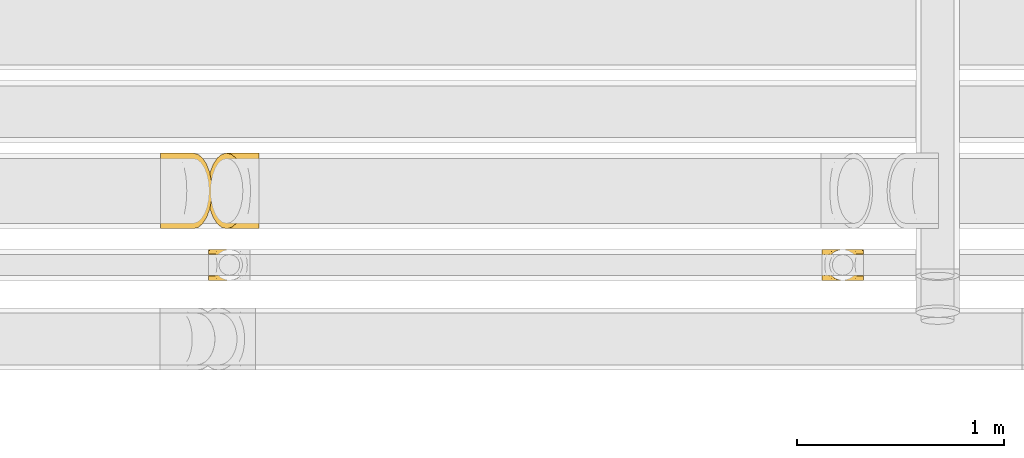
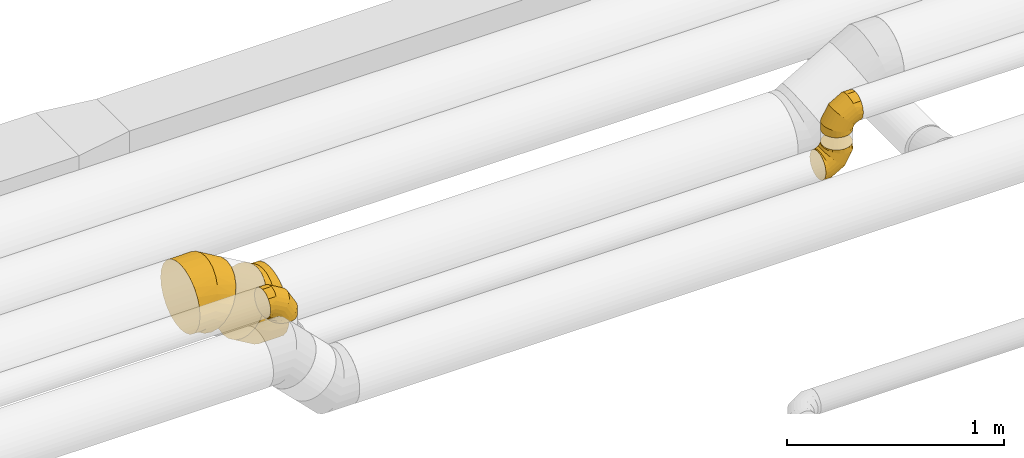
# One storey, part 15 of 92: 5 coverings.
"""IFC2X3 building model written with IfcOpenShell, lengths in millimetres."""

from ifc_helpers import new_model, entity, si_unit, converted_unit, derived_unit, direction, frame, origin, place, context, subcontext, project, spatial, faceted_brep, element, save


model = new_model("IFC2X3")

# Units and contexts
model_context = context("Model", 3, precision=0.01, world=origin(), true_north=direction((6.12303176911189e-17, 1.0)))
body_context = subcontext(model_context, "Body", "Model", "MODEL_VIEW")
ifc_project = project(units=[si_unit("LENGTHUNIT", "METRE", prefix="MILLI"), si_unit("AREAUNIT", "SQUARE_METRE"), si_unit("VOLUMEUNIT", "CUBIC_METRE"), converted_unit("PLANEANGLEUNIT", "DEGREE", entity("IfcRatioMeasure", 0.0174532925199433), si_unit("PLANEANGLEUNIT", "RADIAN"), dimensions=[0, 0, 0, 0, 0, 0, 0]), si_unit("MASSUNIT", "GRAM", prefix="KILO"), derived_unit("MASSDENSITYUNIT", [(si_unit("MASSUNIT", "GRAM", prefix="KILO"), 1), (si_unit("LENGTHUNIT", "METRE"), -3)]), derived_unit("MOMENTOFINERTIAUNIT", [(si_unit("LENGTHUNIT", "METRE"), 4)]), si_unit("TIMEUNIT", "SECOND"), si_unit("FREQUENCYUNIT", "HERTZ"), si_unit("THERMODYNAMICTEMPERATUREUNIT", "DEGREE_CELSIUS"), derived_unit("THERMALTRANSMITTANCEUNIT", [(si_unit("MASSUNIT", "GRAM", prefix="KILO"), 1), (si_unit("THERMODYNAMICTEMPERATUREUNIT", "KELVIN"), -1), (si_unit("TIMEUNIT", "SECOND"), -3)]), derived_unit("VOLUMETRICFLOWRATEUNIT", [(si_unit("LENGTHUNIT", "METRE"), 3), (si_unit("TIMEUNIT", "SECOND"), -1)]), derived_unit("MASSFLOWRATEUNIT", [(si_unit("MASSUNIT", "GRAM", prefix="KILO"), 1), (si_unit("TIMEUNIT", "SECOND"), -1)]), derived_unit("ROTATIONALFREQUENCYUNIT", [(si_unit("TIMEUNIT", "SECOND"), -1)]), si_unit("ELECTRICCURRENTUNIT", "AMPERE"), si_unit("ELECTRICVOLTAGEUNIT", "VOLT"), si_unit("POWERUNIT", "WATT"), si_unit("FORCEUNIT", "NEWTON", prefix="KILO"), si_unit("ILLUMINANCEUNIT", "LUX"), si_unit("LUMINOUSFLUXUNIT", "LUMEN"), si_unit("LUMINOUSINTENSITYUNIT", "CANDELA"), derived_unit("USERDEFINED", [(si_unit("MASSUNIT", "GRAM", prefix="KILO"), -1), (si_unit("LENGTHUNIT", "METRE"), -2), (si_unit("TIMEUNIT", "SECOND"), 3), (si_unit("LUMINOUSFLUXUNIT", "LUMEN"), 1)]), derived_unit("LINEARVELOCITYUNIT", [(si_unit("LENGTHUNIT", "METRE"), 1), (si_unit("TIMEUNIT", "SECOND"), -1)]), si_unit("PRESSUREUNIT", "PASCAL"), derived_unit("USERDEFINED", [(si_unit("LENGTHUNIT", "METRE"), -2), (si_unit("MASSUNIT", "GRAM", prefix="KILO"), 1), (si_unit("TIMEUNIT", "SECOND"), -2)]), derived_unit("LINEARFORCEUNIT", [(si_unit("MASSUNIT", "GRAM", prefix="KILO"), 1), (si_unit("LENGTHUNIT", "METRE"), 1), (si_unit("TIMEUNIT", "SECOND"), -2), (si_unit("LENGTHUNIT", "METRE"), -1)]), derived_unit("PLANARFORCEUNIT", [(si_unit("MASSUNIT", "GRAM", prefix="KILO"), 1), (si_unit("LENGTHUNIT", "METRE"), 1), (si_unit("TIMEUNIT", "SECOND"), -2), (si_unit("LENGTHUNIT", "METRE"), -2)])], contexts=[model_context])

# Site, building, storey
site_placement = place(None, origin())
site = spatial("IfcSite", under=ifc_project, at=site_placement, CompositionType="ELEMENT")
building_placement = place(site_placement, origin())
building = spatial("IfcBuilding", under=site, at=building_placement, CompositionType="ELEMENT")
storey_placement = place(building_placement, frame((0.0, 0.0, 4200.0)))
storey = spatial("IfcBuildingStorey", under=building, at=storey_placement, CompositionType="ELEMENT", Elevation=4200.0)

# Coverings
covering_1_placement = place(storey_placement, frame((33383.87, 14522.9, 3250.0)))
element("IfcCovering", 1, at=covering_1_placement, inside=storey, PredefinedType="INSULATION", context=body_context, shape_type="Brep", body=[
    faceted_brep([(0.0, 47.89, 169.29), (0.0, 62.24, 172.15), (0.0, 76.6, 175.0), (0.0, 90.95, 172.15), (0.0, 105.3, 169.29), (0.0, 117.46, 161.16), (0.0, 129.63, 153.03), (0.0, 137.76, 140.87), (0.0, 145.89, 128.7), (0.0, 148.74, 114.35), (0.0, 151.6, 100.0), (0.0, 148.74, 85.65), (0.0, 145.89, 71.3), (0.0, 137.76, 59.13), (0.0, 129.63, 46.97), (0.0, 117.46, 38.84), (0.0, 105.3, 30.71), (0.0, 90.95, 27.85), (0.0, 83.77, 26.43), (0.0, 76.6, 25.0), (0.0, 69.42, 26.43), (0.0, 62.24, 27.85), (0.0, 47.89, 30.71), (0.0, 35.73, 38.84), (0.0, 23.56, 46.97), (0.0, 15.43, 59.13), (0.0, 7.3, 71.3), (0.0, 4.45, 85.65), (0.0, 1.6, 100.0), (0.0, 4.45, 114.35), (0.0, 7.3, 128.7), (0.0, 15.43, 140.87), (0.0, 23.56, 153.03), (0.0, 35.73, 161.16), (172.44, 96.01, 0.0), (175.0, 76.6, 0.0), (172.44, 57.18, 0.0), (164.95, 39.1, 0.0), (153.03, 23.56, 0.0), (137.5, 11.64, 0.0), (119.41, 4.15, 0.0), (100.0, 1.6, 0.0), (80.59, 4.15, 0.0), (62.5, 11.64, 0.0), (46.97, 23.56, 0.0), (35.05, 39.1, 0.0), (27.56, 57.18, 0.0), (25.0, 76.6, 0.0), (27.56, 96.01, 0.0), (35.05, 114.1, 0.0), (46.97, 129.63, 0.0), (62.5, 141.55, 0.0), (80.59, 149.04, 0.0), (100.0, 151.6, 0.0), (119.41, 149.04, 0.0), (137.5, 141.55, 0.0), (153.03, 129.63, 0.0), (164.95, 114.1, 0.0), (175.0, 76.6, 46.89), (172.44, 57.18, 46.21), (164.95, 39.1, 44.2), (153.03, 23.56, 41.01), (137.5, 11.64, 36.84), (119.41, 4.15, 32.0), (100.0, 1.6, 26.79), (80.59, 4.15, 21.59), (62.5, 11.64, 16.75), (46.97, 23.56, 12.58), (35.05, 39.1, 9.39), (27.56, 57.18, 7.38), (25.0, 76.6, 6.7), (27.56, 96.01, 7.38), (35.05, 114.1, 9.39), (46.97, 129.63, 12.58), (80.59, 149.04, 21.59), (100.0, 151.6, 26.79), (62.5, 141.55, 16.75), (119.41, 149.04, 32.0), (137.5, 141.55, 36.84), (153.03, 129.63, 41.01), (164.95, 114.1, 44.2), (172.44, 96.01, 46.21), (128.11, 76.6, 128.11), (126.24, 57.18, 126.24), (120.75, 39.1, 120.75), (112.03, 23.56, 112.03), (100.66, 11.64, 100.66), (87.42, 4.15, 87.42), (73.21, 1.6, 73.21), (58.99, 4.15, 58.99), (45.75, 11.64, 45.75), (34.38, 23.56, 34.38), (25.66, 39.1, 25.66), (20.17, 57.18, 20.17), (18.3, 76.6, 18.3), (20.17, 96.01, 20.17), (25.66, 114.1, 25.66), (34.38, 129.63, 34.38), (58.99, 149.04, 58.99), (73.21, 151.6, 73.21), (45.75, 141.55, 45.75), (87.42, 149.04, 87.42), (100.66, 141.55, 100.66), (112.03, 129.63, 112.03), (120.75, 114.1, 120.75), (126.24, 96.01, 126.24), (46.89, 76.6, 175.0), (46.21, 57.18, 172.44), (44.2, 39.1, 164.95), (41.01, 23.56, 153.03), (36.84, 11.64, 137.5), (32.0, 4.15, 119.41), (26.79, 1.6, 100.0), (21.59, 4.15, 80.59), (16.75, 11.64, 62.5), (12.58, 23.56, 46.97), (9.39, 39.1, 35.05), (8.39, 48.14, 31.3), (7.38, 57.18, 27.56), (7.04, 66.89, 26.28), (6.7, 76.6, 25.0), (7.38, 96.01, 27.56), (8.39, 105.05, 31.3), (9.39, 114.1, 35.05), (7.04, 86.3, 26.28), (12.58, 129.63, 46.97), (21.59, 149.04, 80.59), (26.79, 151.6, 100.0), (16.75, 141.55, 62.5), (32.0, 149.04, 119.41), (36.84, 141.55, 137.5), (41.01, 129.63, 153.03), (44.2, 114.1, 164.95), (46.21, 96.01, 172.44)], [[[0, 1, 2, 3, 4, 5, 6, 7, 8, 9, 10, 11, 12, 13, 14, 15, 16, 17, 18, 19, 20, 21, 22, 23, 24, 25, 26, 27, 28, 29, 30, 31, 32, 33]], [[34, 35, 36, 37, 38, 39, 40, 41, 42, 43, 44, 45, 46, 47, 48, 49, 50, 51, 52, 53, 54, 55, 56, 57]], [[35, 58, 59, 36]], [[36, 59, 60, 37]], [[37, 60, 61, 38]], [[39, 62, 63, 40]], [[40, 63, 64, 41]], [[38, 61, 62, 39]], [[65, 66, 43, 42]], [[64, 65, 42, 41]], [[67, 44, 43, 66]], [[68, 69, 46, 45]], [[68, 45, 44, 67]], [[70, 47, 46, 69]], [[71, 72, 49, 48]], [[70, 71, 48, 47]], [[50, 49, 72, 73]], [[74, 75, 53, 52]], [[76, 74, 52, 51]], [[73, 76, 51, 50]], [[55, 54, 77, 78]], [[56, 55, 78, 79]], [[53, 75, 77, 54]], [[34, 57, 80, 81]], [[35, 34, 81, 58]], [[79, 80, 57, 56]], [[58, 82, 83, 59]], [[60, 59, 83, 84]], [[84, 85, 61, 60]], [[62, 61, 85, 86]], [[63, 62, 86, 87]], [[64, 63, 87, 88]], [[89, 90, 66, 65]], [[88, 89, 65, 64]], [[67, 66, 90, 91]], [[92, 93, 69, 68]], [[91, 92, 68, 67]], [[70, 69, 93, 94]], [[95, 96, 72, 71]], [[94, 95, 71, 70]], [[73, 72, 96, 97]], [[98, 99, 75, 74]], [[100, 98, 74, 76]], [[97, 100, 76, 73]], [[77, 75, 99, 101]], [[78, 77, 101, 102]], [[79, 78, 102, 103]], [[81, 80, 104, 105]], [[58, 81, 105, 82]], [[103, 104, 80, 79]], [[82, 106, 107, 83]], [[84, 83, 107, 108]], [[108, 109, 85, 84]], [[86, 85, 109, 110]], [[87, 86, 110, 111]], [[88, 87, 111, 112]], [[113, 114, 90, 89]], [[112, 113, 89, 88]], [[91, 90, 114, 115]], [[93, 92, 116, 117, 118]], [[115, 116, 92, 91]], [[94, 93, 118, 119, 120]], [[95, 121, 122, 123, 96]], [[94, 120, 124, 121, 95]], [[97, 96, 123, 125]], [[126, 127, 99, 98]], [[128, 126, 98, 100]], [[125, 128, 100, 97]], [[101, 99, 127, 129]], [[102, 101, 129, 130]], [[103, 102, 130, 131]], [[105, 104, 132, 133]], [[82, 105, 133, 106]], [[131, 132, 104, 103]], [[106, 1, 107]], [[111, 30, 29]], [[1, 106, 2]], [[32, 109, 33]], [[108, 0, 33]], [[107, 0, 108]], [[31, 30, 110]], [[108, 33, 109]], [[31, 109, 32]], [[28, 112, 29]], [[1, 0, 107]], [[112, 111, 29]], [[110, 30, 111]], [[109, 31, 110]], [[113, 28, 27, 26]], [[24, 115, 25]], [[119, 21, 20]], [[114, 26, 25]], [[114, 113, 26]], [[120, 20, 19]], [[114, 25, 115]], [[28, 113, 112]], [[120, 119, 20]], [[21, 119, 118]], [[22, 118, 117, 116]], [[24, 23, 115]], [[115, 23, 116]], [[118, 22, 21]], [[116, 23, 22]], [[121, 17, 16]], [[15, 14, 125]], [[16, 123, 122, 121]], [[18, 17, 124]], [[18, 120, 19]], [[125, 123, 15]], [[13, 125, 14]], [[126, 12, 11, 10]], [[125, 13, 128]], [[120, 18, 124]], [[126, 128, 12]], [[126, 10, 127]], [[17, 121, 124]], [[123, 16, 15]], [[13, 12, 128]], [[127, 9, 129]], [[6, 131, 7]], [[130, 8, 7]], [[129, 8, 130]], [[5, 131, 6]], [[9, 8, 129]], [[130, 7, 131]], [[9, 127, 10]], [[133, 4, 3]], [[131, 5, 132]], [[2, 106, 3]], [[4, 133, 132]], [[106, 133, 3]], [[5, 4, 132]]]),
])
covering_2_placement = place(storey_placement, frame((36345.15, 14522.9, 3013.4)))
element("IfcCovering", 2, at=covering_2_placement, inside=storey, PredefinedType="INSULATION", context=body_context, shape_type="Brep", body=[
    faceted_brep([(140.87, 15.43, 176.6), (153.03, 23.56, 176.6), (161.16, 35.73, 176.6), (169.29, 47.89, 176.6), (172.15, 62.24, 176.6), (175.0, 76.6, 176.6), (172.15, 90.95, 176.6), (169.29, 105.3, 176.6), (161.16, 117.46, 176.6), (153.03, 129.63, 176.6), (140.87, 137.76, 176.6), (128.7, 145.89, 176.6), (114.35, 148.74, 176.6), (100.0, 151.6, 176.6), (85.65, 148.74, 176.6), (71.3, 145.89, 176.6), (59.13, 137.76, 176.6), (46.97, 129.63, 176.6), (38.84, 117.46, 176.6), (30.71, 105.3, 176.6), (27.85, 90.95, 176.6), (26.43, 83.77, 176.6), (25.0, 76.6, 176.6), (26.43, 69.42, 176.6), (27.85, 62.24, 176.6), (30.71, 47.89, 176.6), (38.84, 35.73, 176.6), (46.97, 23.56, 176.6), (59.13, 15.43, 176.6), (71.3, 7.3, 176.6), (85.65, 4.45, 176.6), (100.0, 1.6, 176.6), (114.35, 4.45, 176.6), (128.7, 7.3, 176.6), (0.0, 96.01, 4.15), (0.0, 76.6, 1.6), (0.0, 57.18, 4.15), (0.0, 39.1, 11.64), (0.0, 23.56, 23.56), (0.0, 11.64, 39.1), (0.0, 4.15, 57.18), (0.0, 1.6, 76.6), (0.0, 4.15, 96.01), (0.0, 11.64, 114.1), (0.0, 23.56, 129.63), (0.0, 39.1, 141.55), (0.0, 57.18, 149.04), (0.0, 76.6, 151.6), (0.0, 96.01, 149.04), (0.0, 114.1, 141.55), (0.0, 129.63, 129.63), (0.0, 141.55, 114.1), (0.0, 149.04, 96.01), (0.0, 151.6, 76.6), (0.0, 149.04, 57.18), (0.0, 141.55, 39.1), (0.0, 129.63, 23.56), (0.0, 114.1, 11.64), (46.89, 76.6, 1.6), (46.21, 57.18, 4.15), (44.2, 39.1, 11.64), (41.01, 23.56, 23.56), (36.84, 11.64, 39.1), (32.0, 4.15, 57.18), (26.79, 1.6, 76.6), (21.59, 4.15, 96.01), (16.75, 11.64, 114.1), (12.58, 23.56, 129.63), (9.39, 39.1, 141.55), (7.38, 57.18, 149.04), (6.7, 76.6, 151.6), (7.38, 96.01, 149.04), (9.39, 114.1, 141.55), (12.58, 129.63, 129.63), (21.59, 149.04, 96.01), (26.79, 151.6, 76.6), (16.75, 141.55, 114.1), (32.0, 149.04, 57.18), (36.84, 141.55, 39.1), (41.01, 129.63, 23.56), (44.2, 114.1, 11.64), (46.21, 96.01, 4.15), (128.11, 76.6, 48.49), (126.24, 57.18, 50.36), (120.75, 39.1, 55.84), (112.03, 23.56, 64.57), (100.66, 11.64, 75.94), (87.42, 4.15, 89.18), (73.21, 1.6, 103.39), (58.99, 4.15, 117.6), (45.75, 11.64, 130.84), (34.38, 23.56, 142.21), (25.66, 39.1, 150.94), (20.17, 57.18, 156.42), (18.3, 76.6, 158.29), (20.17, 96.01, 156.42), (25.66, 114.1, 150.94), (34.38, 129.63, 142.21), (58.99, 149.04, 117.6), (73.21, 151.6, 103.39), (45.75, 141.55, 130.84), (87.42, 149.04, 89.18), (100.66, 141.55, 75.94), (112.03, 129.63, 64.57), (120.75, 114.1, 55.84), (126.24, 96.01, 50.36), (175.0, 76.6, 129.7), (172.44, 57.18, 130.39), (164.95, 39.1, 132.4), (153.03, 23.56, 135.59), (137.5, 11.64, 139.75), (119.41, 4.15, 144.6), (100.0, 1.6, 149.8), (80.59, 4.15, 155.0), (62.5, 11.64, 159.85), (46.97, 23.56, 164.01), (35.05, 39.1, 167.2), (31.3, 48.14, 168.21), (27.56, 57.18, 169.21), (26.28, 66.89, 169.55), (25.0, 76.6, 169.9), (27.56, 96.01, 169.21), (31.3, 105.05, 168.21), (35.05, 114.1, 167.2), (26.28, 86.3, 169.55), (46.97, 129.63, 164.01), (80.59, 149.04, 155.0), (100.0, 151.6, 149.8), (62.5, 141.55, 159.85), (119.41, 149.04, 144.6), (137.5, 141.55, 139.75), (153.03, 129.63, 135.59), (164.95, 114.1, 132.4), (172.44, 96.01, 130.39)], [[[0, 1, 2, 3, 4, 5, 6, 7, 8, 9, 10, 11, 12, 13, 14, 15, 16, 17, 18, 19, 20, 21, 22, 23, 24, 25, 26, 27, 28, 29, 30, 31, 32, 33]], [[34, 35, 36, 37, 38, 39, 40, 41, 42, 43, 44, 45, 46, 47, 48, 49, 50, 51, 52, 53, 54, 55, 56, 57]], [[35, 58, 59, 36]], [[36, 59, 60, 37]], [[37, 60, 61, 38]], [[39, 62, 63, 40]], [[40, 63, 64, 41]], [[38, 61, 62, 39]], [[65, 66, 43, 42]], [[64, 65, 42, 41]], [[67, 44, 43, 66]], [[68, 69, 46, 45]], [[68, 45, 44, 67]], [[70, 47, 46, 69]], [[71, 72, 49, 48]], [[70, 71, 48, 47]], [[50, 49, 72, 73]], [[74, 75, 53, 52]], [[76, 74, 52, 51]], [[73, 76, 51, 50]], [[55, 54, 77, 78]], [[56, 55, 78, 79]], [[53, 75, 77, 54]], [[34, 57, 80, 81]], [[35, 34, 81, 58]], [[79, 80, 57, 56]], [[58, 82, 83, 59]], [[60, 59, 83, 84]], [[84, 85, 61, 60]], [[62, 61, 85, 86]], [[63, 62, 86, 87]], [[64, 63, 87, 88]], [[89, 90, 66, 65]], [[88, 89, 65, 64]], [[67, 66, 90, 91]], [[92, 93, 69, 68]], [[91, 92, 68, 67]], [[70, 69, 93, 94]], [[95, 96, 72, 71]], [[94, 95, 71, 70]], [[73, 72, 96, 97]], [[98, 99, 75, 74]], [[100, 98, 74, 76]], [[97, 100, 76, 73]], [[77, 75, 99, 101]], [[78, 77, 101, 102]], [[79, 78, 102, 103]], [[81, 80, 104, 105]], [[58, 81, 105, 82]], [[103, 104, 80, 79]], [[82, 106, 107, 83]], [[84, 83, 107, 108]], [[108, 109, 85, 84]], [[86, 85, 109, 110]], [[87, 86, 110, 111]], [[88, 87, 111, 112]], [[113, 114, 90, 89]], [[112, 113, 89, 88]], [[91, 90, 114, 115]], [[93, 92, 116, 117, 118]], [[115, 116, 92, 91]], [[94, 93, 118, 119, 120]], [[95, 121, 122, 123, 96]], [[94, 120, 124, 121, 95]], [[97, 96, 123, 125]], [[126, 127, 99, 98]], [[128, 126, 98, 100]], [[125, 128, 100, 97]], [[101, 99, 127, 129]], [[102, 101, 129, 130]], [[103, 102, 130, 131]], [[105, 104, 132, 133]], [[82, 105, 133, 106]], [[131, 132, 104, 103]], [[106, 4, 107]], [[111, 33, 32]], [[4, 106, 5]], [[1, 109, 2]], [[108, 3, 2]], [[107, 3, 108]], [[0, 33, 110]], [[108, 2, 109]], [[0, 109, 1]], [[31, 112, 32]], [[4, 3, 107]], [[112, 111, 32]], [[110, 33, 111]], [[109, 0, 110]], [[113, 31, 30, 29]], [[27, 115, 28]], [[119, 24, 23]], [[114, 29, 28]], [[114, 113, 29]], [[120, 23, 22]], [[114, 28, 115]], [[31, 113, 112]], [[120, 119, 23]], [[24, 119, 118]], [[25, 118, 117, 116]], [[27, 26, 115]], [[115, 26, 116]], [[118, 25, 24]], [[116, 26, 25]], [[121, 20, 19]], [[18, 17, 125]], [[19, 123, 122, 121]], [[21, 20, 124]], [[21, 120, 22]], [[125, 123, 18]], [[16, 125, 17]], [[126, 15, 14, 13]], [[125, 16, 128]], [[120, 21, 124]], [[126, 128, 15]], [[126, 13, 127]], [[20, 121, 124]], [[123, 19, 18]], [[16, 15, 128]], [[127, 12, 129]], [[9, 131, 10]], [[130, 11, 10]], [[129, 11, 130]], [[8, 131, 9]], [[12, 11, 129]], [[130, 10, 131]], [[12, 127, 13]], [[133, 7, 6]], [[131, 8, 132]], [[5, 106, 6]], [[7, 133, 132]], [[106, 133, 6]], [[8, 7, 132]]]),
])
covering_3_placement = place(storey_placement, frame((36368.56, 14522.9, 3259.48)))
element("IfcCovering", 3, at=covering_3_placement, inside=storey, PredefinedType="INSULATION", context=body_context, shape_type="Brep", body=[
    faceted_brep([(176.6, 105.3, 169.29), (176.6, 90.95, 172.15), (176.6, 76.6, 175.0), (176.6, 62.24, 172.15), (176.6, 47.89, 169.29), (176.6, 35.73, 161.16), (176.6, 23.56, 153.03), (176.6, 15.43, 140.87), (176.6, 7.3, 128.7), (176.6, 4.45, 114.35), (176.6, 1.6, 100.0), (176.6, 4.45, 85.65), (176.6, 7.3, 71.3), (176.6, 15.43, 59.13), (176.6, 23.56, 46.97), (176.6, 35.73, 38.84), (176.6, 47.89, 30.71), (176.6, 62.24, 27.85), (176.6, 69.42, 26.43), (176.6, 76.6, 25.0), (176.6, 83.77, 26.43), (176.6, 90.95, 27.85), (176.6, 105.3, 30.71), (176.6, 117.46, 38.84), (176.6, 129.63, 46.97), (176.6, 137.76, 59.13), (176.6, 145.89, 71.3), (176.6, 148.74, 85.65), (176.6, 151.6, 100.0), (176.6, 148.74, 114.35), (176.6, 145.89, 128.7), (176.6, 137.76, 140.87), (176.6, 129.63, 153.03), (176.6, 117.46, 161.16), (4.15, 57.18, 0.0), (1.6, 76.6, 0.0), (4.15, 96.01, 0.0), (11.64, 114.1, 0.0), (23.56, 129.63, 0.0), (39.1, 141.55, 0.0), (57.18, 149.04, 0.0), (76.6, 151.6, 0.0), (96.01, 149.04, 0.0), (114.1, 141.55, 0.0), (129.63, 129.63, 0.0), (141.55, 114.1, 0.0), (149.04, 96.01, 0.0), (151.6, 76.6, 0.0), (149.04, 57.18, 0.0), (141.55, 39.1, 0.0), (129.63, 23.56, 0.0), (114.1, 11.64, 0.0), (96.01, 4.15, 0.0), (76.6, 1.6, 0.0), (57.18, 4.15, 0.0), (39.1, 11.64, 0.0), (23.56, 23.56, 0.0), (11.64, 39.1, 0.0), (1.6, 76.6, 46.89), (4.15, 96.01, 46.21), (11.64, 114.1, 44.2), (23.56, 129.63, 41.01), (39.1, 141.55, 36.84), (57.18, 149.04, 32.0), (76.6, 151.6, 26.79), (96.01, 149.04, 21.59), (114.1, 141.55, 16.75), (129.63, 129.63, 12.58), (141.55, 114.1, 9.39), (149.04, 96.01, 7.38), (151.6, 76.6, 6.7), (149.04, 57.18, 7.38), (141.55, 39.1, 9.39), (129.63, 23.56, 12.58), (96.01, 4.15, 21.59), (76.6, 1.6, 26.79), (114.1, 11.64, 16.75), (57.18, 4.15, 32.0), (39.1, 11.64, 36.84), (23.56, 23.56, 41.01), (11.64, 39.1, 44.2), (4.15, 57.18, 46.21), (48.49, 76.6, 128.11), (50.36, 96.01, 126.24), (55.84, 114.1, 120.75), (64.57, 129.63, 112.03), (75.94, 141.55, 100.66), (89.18, 149.04, 87.42), (103.39, 151.6, 73.21), (117.6, 149.04, 58.99), (130.84, 141.55, 45.75), (142.21, 129.63, 34.38), (150.94, 114.1, 25.66), (156.42, 96.01, 20.17), (158.29, 76.6, 18.3), (156.42, 57.18, 20.17), (150.94, 39.1, 25.66), (142.21, 23.56, 34.38), (117.6, 4.15, 58.99), (103.39, 1.6, 73.21), (130.84, 11.64, 45.75), (89.18, 4.15, 87.42), (75.94, 11.64, 100.66), (64.57, 23.56, 112.03), (55.84, 39.1, 120.75), (50.36, 57.18, 126.24), (129.7, 76.6, 175.0), (130.39, 96.01, 172.44), (132.4, 114.1, 164.95), (135.59, 129.63, 153.03), (139.75, 141.55, 137.5), (144.6, 149.04, 119.41), (149.8, 151.6, 100.0), (155.0, 149.04, 80.59), (159.85, 141.55, 62.5), (164.01, 129.63, 46.97), (167.2, 114.1, 35.05), (168.21, 105.05, 31.3), (169.21, 96.01, 27.56), (169.55, 86.3, 26.28), (169.9, 76.6, 25.0), (169.21, 57.18, 27.56), (168.21, 48.14, 31.3), (167.2, 39.1, 35.05), (169.55, 66.89, 26.28), (164.01, 23.56, 46.97), (155.0, 4.15, 80.59), (149.8, 1.6, 100.0), (159.85, 11.64, 62.5), (144.6, 4.15, 119.41), (139.75, 11.64, 137.5), (135.59, 23.56, 153.03), (132.4, 39.1, 164.95), (130.39, 57.18, 172.44)], [[[0, 1, 2, 3, 4, 5, 6, 7, 8, 9, 10, 11, 12, 13, 14, 15, 16, 17, 18, 19, 20, 21, 22, 23, 24, 25, 26, 27, 28, 29, 30, 31, 32, 33]], [[34, 35, 36, 37, 38, 39, 40, 41, 42, 43, 44, 45, 46, 47, 48, 49, 50, 51, 52, 53, 54, 55, 56, 57]], [[35, 58, 59, 36]], [[36, 59, 60, 37]], [[37, 60, 61, 38]], [[39, 62, 63, 40]], [[40, 63, 64, 41]], [[38, 61, 62, 39]], [[65, 66, 43, 42]], [[64, 65, 42, 41]], [[67, 44, 43, 66]], [[68, 69, 46, 45]], [[68, 45, 44, 67]], [[70, 47, 46, 69]], [[71, 72, 49, 48]], [[70, 71, 48, 47]], [[50, 49, 72, 73]], [[74, 75, 53, 52]], [[76, 74, 52, 51]], [[73, 76, 51, 50]], [[55, 54, 77, 78]], [[56, 55, 78, 79]], [[53, 75, 77, 54]], [[34, 57, 80, 81]], [[35, 34, 81, 58]], [[79, 80, 57, 56]], [[58, 82, 83, 59]], [[60, 59, 83, 84]], [[84, 85, 61, 60]], [[62, 61, 85, 86]], [[63, 62, 86, 87]], [[64, 63, 87, 88]], [[89, 90, 66, 65]], [[88, 89, 65, 64]], [[67, 66, 90, 91]], [[92, 93, 69, 68]], [[91, 92, 68, 67]], [[70, 69, 93, 94]], [[95, 96, 72, 71]], [[94, 95, 71, 70]], [[73, 72, 96, 97]], [[98, 99, 75, 74]], [[100, 98, 74, 76]], [[97, 100, 76, 73]], [[77, 75, 99, 101]], [[78, 77, 101, 102]], [[79, 78, 102, 103]], [[81, 80, 104, 105]], [[58, 81, 105, 82]], [[103, 104, 80, 79]], [[82, 106, 107, 83]], [[84, 83, 107, 108]], [[108, 109, 85, 84]], [[86, 85, 109, 110]], [[87, 86, 110, 111]], [[88, 87, 111, 112]], [[113, 114, 90, 89]], [[112, 113, 89, 88]], [[91, 90, 114, 115]], [[93, 92, 116, 117, 118]], [[115, 116, 92, 91]], [[94, 93, 118, 119, 120]], [[95, 121, 122, 123, 96]], [[94, 120, 124, 121, 95]], [[97, 96, 123, 125]], [[126, 127, 99, 98]], [[128, 126, 98, 100]], [[125, 128, 100, 97]], [[101, 99, 127, 129]], [[102, 101, 129, 130]], [[103, 102, 130, 131]], [[105, 104, 132, 133]], [[82, 105, 133, 106]], [[131, 132, 104, 103]], [[106, 1, 107]], [[111, 30, 29]], [[1, 106, 2]], [[32, 109, 33]], [[108, 0, 33]], [[107, 0, 108]], [[31, 30, 110]], [[108, 33, 109]], [[31, 109, 32]], [[28, 112, 29]], [[1, 0, 107]], [[112, 111, 29]], [[110, 30, 111]], [[109, 31, 110]], [[113, 28, 27, 26]], [[24, 115, 25]], [[119, 21, 20]], [[114, 26, 25]], [[114, 113, 26]], [[120, 20, 19]], [[114, 25, 115]], [[28, 113, 112]], [[120, 119, 20]], [[21, 119, 118]], [[22, 118, 117, 116]], [[24, 23, 115]], [[115, 23, 116]], [[118, 22, 21]], [[116, 23, 22]], [[121, 17, 16]], [[15, 14, 125]], [[16, 123, 122, 121]], [[18, 17, 124]], [[18, 120, 19]], [[125, 123, 15]], [[13, 125, 14]], [[126, 12, 11, 10]], [[125, 13, 128]], [[120, 18, 124]], [[126, 128, 12]], [[126, 10, 127]], [[17, 121, 124]], [[123, 16, 15]], [[13, 12, 128]], [[127, 9, 129]], [[6, 131, 7]], [[130, 8, 7]], [[129, 8, 130]], [[5, 131, 6]], [[9, 8, 129]], [[130, 7, 131]], [[9, 127, 10]], [[133, 4, 3]], [[131, 5, 132]], [[2, 106, 3]], [[4, 133, 132]], [[106, 133, 3]], [[5, 4, 132]]]),
])
covering_4_placement = place(storey_placement, frame((33377.74, 14772.9, 2885.9)))
element("IfcCovering", 4, at=covering_4_placement, inside=storey, PredefinedType="INSULATION", context=body_context, shape_type="Brep", body=[
    faceted_brep([(180.99, 136.86, 378.96), (184.1, 184.1, 384.35), (180.99, 231.33, 378.96), (171.87, 275.35, 363.17), (157.37, 313.14, 338.06), (138.47, 342.14, 305.32), (116.46, 360.38, 267.2), (92.85, 366.6, 226.3), (69.23, 360.38, 185.39), (47.22, 342.14, 147.27), (28.32, 313.14, 114.54), (13.82, 275.35, 89.42), (4.7, 231.33, 73.63), (1.6, 184.1, 68.25), (4.7, 136.86, 73.63), (13.82, 92.85, 89.42), (28.32, 55.05, 114.54), (47.22, 26.05, 147.27), (69.23, 7.81, 185.39), (92.85, 1.6, 226.3), (116.46, 7.81, 267.2), (138.47, 26.05, 305.32), (157.37, 55.05, 338.06), (171.87, 92.85, 363.17), (250.35, 92.85, 26.05), (250.35, 136.86, 7.81), (250.35, 184.1, 1.6), (250.35, 231.33, 7.81), (250.35, 275.35, 26.05), (250.35, 313.14, 55.05), (250.35, 342.14, 92.85), (250.35, 360.38, 136.86), (250.35, 366.6, 184.1), (250.35, 360.38, 231.33), (250.35, 342.14, 275.35), (250.35, 313.14, 313.14), (250.35, 275.35, 342.14), (250.35, 231.33, 360.38), (250.35, 184.1, 366.6), (250.35, 136.86, 360.38), (250.35, 92.85, 342.14), (250.35, 55.05, 313.14), (250.35, 26.05, 275.35), (250.35, 7.81, 231.33), (250.35, 1.6, 184.1), (250.35, 7.81, 136.86), (250.35, 26.05, 92.85), (250.35, 55.05, 55.05), (117.04, 184.1, 1.6), (118.27, 224.71, 6.17), (121.88, 263.28, 19.67), (127.71, 297.88, 41.41), (135.45, 326.78, 70.31), (144.72, 348.52, 104.91), (155.06, 362.02, 143.49), (165.94, 366.6, 184.1), (176.82, 362.02, 224.71), (187.16, 348.52, 263.28), (196.43, 326.78, 297.88), (204.17, 297.88, 326.78), (210.0, 263.28, 348.52), (213.62, 224.71, 362.02), (214.84, 184.1, 366.6), (210.0, 104.91, 348.52), (204.17, 70.31, 326.78), (213.62, 143.49, 362.02), (196.43, 41.41, 297.88), (187.16, 19.67, 263.28), (176.82, 6.17, 224.71), (165.94, 1.6, 184.1), (155.06, 6.17, 143.49), (144.72, 19.67, 104.91), (135.45, 41.41, 70.31), (127.71, 70.31, 41.41), (121.88, 104.91, 19.67), (118.27, 143.49, 6.17)], [[[0, 1, 2, 3, 4, 5, 6, 7, 8, 9, 10, 11, 12, 13, 14, 15, 16, 17, 18, 19, 20, 21, 22, 23]], [[24, 25, 26, 27, 28, 29, 30, 31, 32, 33, 34, 35, 36, 37, 38, 39, 40, 41, 42, 43, 44, 45, 46, 47]], [[26, 48, 49]], [[27, 49, 50]], [[26, 49, 27]], [[28, 51, 29]], [[28, 27, 50]], [[51, 28, 50]], [[30, 52, 53]], [[31, 53, 54]], [[32, 54, 55]], [[29, 52, 30]], [[30, 53, 31]], [[54, 32, 31]], [[52, 29, 51]], [[56, 57, 33]], [[55, 56, 32]], [[32, 56, 33]], [[34, 58, 35]], [[34, 33, 57]], [[58, 34, 57]], [[59, 60, 36]], [[61, 62, 38]], [[60, 61, 37]], [[35, 59, 36]], [[36, 60, 37]], [[61, 38, 37]], [[59, 35, 58]], [[63, 64, 40]], [[65, 63, 39]], [[62, 65, 38]], [[38, 65, 39]], [[63, 40, 39]], [[64, 41, 40]], [[66, 67, 42]], [[68, 69, 44]], [[67, 68, 43]], [[41, 66, 42]], [[42, 67, 43]], [[68, 44, 43]], [[66, 41, 64]], [[45, 70, 71]], [[46, 71, 72]], [[69, 70, 44]], [[44, 70, 45]], [[71, 46, 45]], [[72, 47, 46]], [[24, 73, 74]], [[74, 75, 25]], [[48, 26, 75]], [[47, 73, 24]], [[24, 74, 25]], [[75, 26, 25]], [[73, 47, 72]], [[49, 13, 12]], [[50, 12, 11]], [[48, 13, 49]], [[49, 12, 50]], [[11, 51, 50]], [[11, 10, 51]], [[52, 10, 9]], [[53, 9, 8]], [[54, 8, 7]], [[52, 9, 53]], [[53, 8, 54]], [[7, 55, 54]], [[10, 52, 51]], [[56, 7, 6]], [[57, 6, 5]], [[56, 55, 7]], [[58, 57, 5]], [[56, 6, 57]], [[5, 4, 58]], [[59, 4, 3]], [[60, 3, 2]], [[61, 2, 1]], [[60, 59, 3]], [[62, 61, 1]], [[60, 2, 61]], [[4, 59, 58]], [[65, 1, 0]], [[63, 0, 23]], [[65, 62, 1]], [[64, 63, 23]], [[65, 0, 63]], [[23, 22, 64]], [[66, 22, 21]], [[67, 21, 20]], [[68, 20, 19]], [[67, 66, 21]], [[69, 68, 19]], [[67, 20, 68]], [[22, 66, 64]], [[70, 19, 18]], [[71, 18, 17]], [[69, 19, 70]], [[71, 70, 18]], [[72, 71, 17]], [[17, 16, 72]], [[73, 16, 15]], [[74, 15, 14]], [[75, 14, 13]], [[73, 15, 74]], [[75, 74, 14]], [[48, 75, 13]], [[16, 73, 72]]]),
])
covering_5_placement = place(storey_placement, frame((33151.84, 14772.9, 3045.65)))
element("IfcCovering", 5, at=covering_5_placement, inside=storey, PredefinedType="INSULATION", context=body_context, shape_type="Brep", body=[
    faceted_brep([(0.0, 136.86, 25.57), (0.0, 92.85, 43.8), (0.0, 55.05, 72.8), (0.0, 26.05, 110.6), (0.0, 7.81, 154.61), (0.0, 1.6, 201.85), (0.0, 7.81, 249.08), (0.0, 26.05, 293.1), (0.0, 55.05, 330.89), (0.0, 92.85, 359.9), (0.0, 136.86, 378.13), (0.0, 184.1, 384.35), (0.0, 231.33, 378.13), (0.0, 275.35, 359.9), (0.0, 313.14, 330.89), (0.0, 342.14, 293.1), (0.0, 360.38, 249.08), (0.0, 366.6, 201.85), (0.0, 360.38, 154.61), (0.0, 342.14, 110.6), (0.0, 313.14, 72.8), (0.0, 275.35, 43.8), (0.0, 231.33, 25.57), (0.0, 184.1, 19.35), (236.52, 275.35, 296.52), (245.64, 231.33, 312.31), (248.75, 184.1, 317.69), (245.64, 136.86, 312.31), (236.52, 92.85, 296.52), (222.02, 55.05, 271.4), (203.13, 26.05, 238.67), (181.12, 7.81, 200.55), (157.5, 1.6, 159.64), (133.88, 7.81, 118.74), (111.88, 26.05, 80.62), (92.98, 55.05, 47.89), (78.48, 92.85, 22.77), (69.36, 136.86, 6.98), (66.25, 184.1, 1.6), (69.36, 231.33, 6.98), (78.48, 275.35, 22.77), (92.98, 313.14, 47.89), (111.88, 342.14, 80.62), (133.88, 360.38, 118.74), (157.5, 366.6, 159.64), (181.12, 360.38, 200.55), (203.13, 342.14, 238.67), (222.02, 313.14, 271.4), (133.3, 184.1, 384.35), (132.08, 143.49, 379.77), (128.46, 104.91, 366.27), (122.64, 70.31, 344.53), (114.89, 41.41, 315.63), (105.62, 19.67, 281.03), (95.29, 6.17, 242.46), (84.4, 1.6, 201.85), (73.52, 6.17, 161.24), (63.19, 19.67, 122.66), (53.91, 41.41, 88.06), (46.17, 70.31, 59.16), (40.35, 104.91, 37.42), (36.73, 143.49, 23.92), (35.5, 184.1, 19.35), (40.35, 263.28, 37.42), (46.17, 297.88, 59.16), (36.73, 224.71, 23.92), (53.91, 326.78, 88.06), (63.19, 348.52, 122.66), (73.52, 362.02, 161.24), (84.4, 366.6, 201.85), (95.29, 362.02, 242.46), (105.62, 348.52, 281.03), (114.89, 326.78, 315.63), (122.64, 297.88, 344.53), (128.46, 263.28, 366.27), (132.08, 224.71, 379.77)], [[[0, 1, 2, 3, 4, 5, 6, 7, 8, 9, 10, 11, 12, 13, 14, 15, 16, 17, 18, 19, 20, 21, 22, 23]], [[24, 25, 26, 27, 28, 29, 30, 31, 32, 33, 34, 35, 36, 37, 38, 39, 40, 41, 42, 43, 44, 45, 46, 47]], [[26, 48, 49]], [[27, 49, 50]], [[26, 49, 27]], [[28, 51, 29]], [[28, 27, 50]], [[51, 28, 50]], [[30, 52, 53]], [[31, 53, 54]], [[32, 54, 55]], [[29, 52, 30]], [[30, 53, 31]], [[54, 32, 31]], [[52, 29, 51]], [[56, 57, 33]], [[55, 56, 32]], [[32, 56, 33]], [[34, 58, 35]], [[34, 33, 57]], [[58, 34, 57]], [[59, 60, 36]], [[61, 62, 38]], [[60, 61, 37]], [[35, 59, 36]], [[36, 60, 37]], [[61, 38, 37]], [[59, 35, 58]], [[63, 64, 40]], [[65, 63, 39]], [[62, 65, 38]], [[38, 65, 39]], [[63, 40, 39]], [[64, 41, 40]], [[66, 67, 42]], [[68, 69, 44]], [[67, 68, 43]], [[41, 66, 42]], [[42, 67, 43]], [[68, 44, 43]], [[66, 41, 64]], [[45, 70, 71]], [[46, 71, 72]], [[69, 70, 44]], [[44, 70, 45]], [[71, 46, 45]], [[72, 47, 46]], [[24, 73, 74]], [[74, 75, 25]], [[48, 26, 75]], [[47, 73, 24]], [[24, 74, 25]], [[75, 26, 25]], [[73, 47, 72]], [[49, 11, 10]], [[50, 10, 9]], [[48, 11, 49]], [[49, 10, 50]], [[9, 51, 50]], [[9, 8, 51]], [[52, 8, 7]], [[53, 7, 6]], [[54, 6, 5]], [[52, 7, 53]], [[53, 6, 54]], [[5, 55, 54]], [[8, 52, 51]], [[56, 5, 4]], [[57, 4, 3]], [[56, 55, 5]], [[58, 57, 3]], [[56, 4, 57]], [[3, 2, 58]], [[59, 2, 1]], [[60, 1, 0]], [[61, 0, 23]], [[60, 59, 1]], [[62, 61, 23]], [[60, 0, 61]], [[2, 59, 58]], [[65, 23, 22]], [[63, 22, 21]], [[65, 62, 23]], [[64, 63, 21]], [[65, 22, 63]], [[21, 20, 64]], [[66, 20, 19]], [[67, 19, 18]], [[68, 18, 17]], [[67, 66, 19]], [[69, 68, 17]], [[67, 18, 68]], [[20, 66, 64]], [[70, 17, 16]], [[71, 16, 15]], [[69, 17, 70]], [[71, 70, 16]], [[72, 71, 15]], [[15, 14, 72]], [[73, 14, 13]], [[74, 13, 12]], [[75, 12, 11]], [[73, 13, 74]], [[75, 74, 12]], [[48, 75, 11]], [[14, 73, 72]]]),
])

save(model, "model.ifc")
